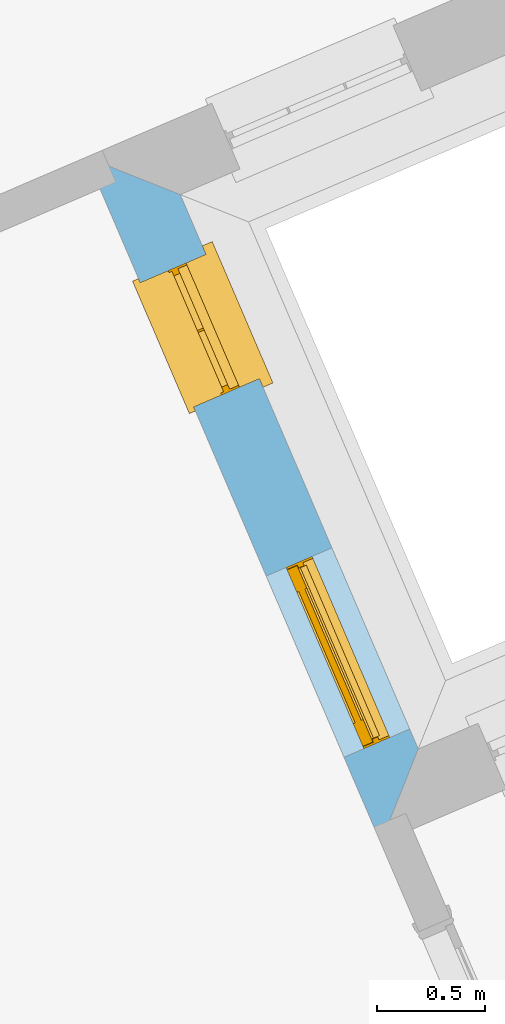
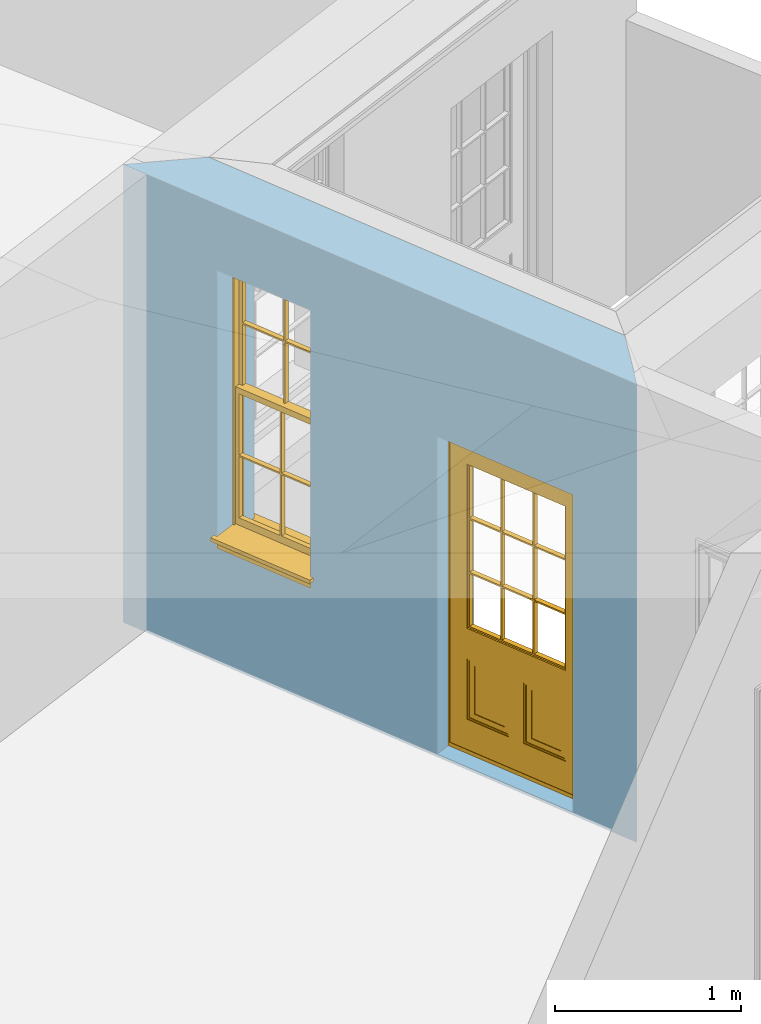
# One storey, part 12 of 19: 1 door, 1 window, 2 openings, plus 1 element that does not belong to this part.
"""IFC2X3 building model written with IfcOpenShell, lengths in metres."""

from ifc_helpers import new_model, si_unit, frame, origin, place, context, subcontext, project, spatial, polyline, outline, extrude, faceted_brep, material, layer, layer_set, layer_usage, element, fill, save


model = new_model("IFC2X3")

# Units and contexts
model_context = context("Model", 3, world=origin())
body_context = subcontext(model_context, "Body", "Model", "MODEL_VIEW")
ifc_project = project(units=[si_unit("PLANEANGLEUNIT", "RADIAN"), si_unit("MASSUNIT", "GRAM", prefix="KILO"), si_unit("FORCEUNIT", "NEWTON", prefix="KILO"), si_unit("LENGTHUNIT", "METRE")], contexts=[model_context])

# Site, building, storey
site_placement = place(None, origin())
site = spatial("IfcSite", under=ifc_project, at=site_placement, CompositionType="ELEMENT")
building_placement = place(None, origin())
building = spatial("IfcBuilding", under=site, at=building_placement, Name="Building plot-0", CompositionType="ELEMENT")
storey_placement = place(None, origin())
storey = spatial("IfcBuildingStorey", under=building, at=storey_placement, Name="Floor 0", CompositionType="ELEMENT", Elevation=0.0)

# Wall, openings, door, window
ifc_material = material(Name="Masonry")
ifc_layer = layer(ifc_material, 0.33, ventilated=False)
ifc_layer_set = layer_set([ifc_layer], Name="My Wall")
ifc_layer_usage = layer_usage(ifc_layer_set, "AXIS2", "NEGATIVE", 0.08)
wall_placement = place(storey_placement, origin())
wall = element("IfcWallStandardCase", 1, at=wall_placement, inside=storey, material=ifc_layer_usage, Name="exterior", context=body_context, shape_type="SweptSolid", body=[
    extrude(outline(polyline([(21.6255021072185, 29.8612650519367), (21.7985578106213, 30.2946836988818), (20.7003749450695, 32.8527272164698), (20.2669562981244, 33.0257829198726), (21.6255021072185, 29.8612650519367)])), origin(), (0.0, 0.0, 1.0), 3.0),
])
opening_1_placement = place(storey_placement, frame((0.0, 0.0, 0.02)))
opening_1 = element("IfcOpeningElement", 2, at=opening_1_placement, cuts=wall, Name="Opening", ObjectType="Opening", context=body_context, shape_type="SweptSolid", body=[
    extrude(outline(polyline([(21.7591088797815, 30.3865737519649), (21.4001236091397, 31.2227732350203), (21.0968864339658, 31.0925917632491), (21.4558717046075, 30.2563922801937), (21.7591088797815, 30.3865737519649)])), origin(), (0.0, 0.0, 1.0), 2.08),
])
opening_2_placement = place(storey_placement, frame((0.0, 0.0, 0.75)))
opening_2 = element("IfcOpeningElement", 3, at=opening_2_placement, cuts=wall, Name="Opening", ObjectType="Opening", context=body_context, shape_type="SweptSolid", body=[
    extrude(outline(polyline([(21.0652775553373, 32.0027442254519), (20.8187217375888, 32.5770570572208), (20.5154845624148, 32.4468755854496), (20.7620403801633, 31.8725627536807), (21.0652775553373, 32.0027442254519)])), origin(), (0.0, 0.0, 1.0), 1.82),
])
door_placement = place(storey_placement, frame((21.529383747074, 30.2879514248655, 0.02), z_axis=(0.0, 0.0, 1.0), x_axis=(-0.358985270641764, 0.836199483055484, 0.0)))
door = element("IfcDoor", 4, at=door_placement, inside=storey, Name="circulation outside door", OverallHeight=2.08, OverallWidth=0.91, context=body_context, shape_type="Brep", held_by="IfcProductRepresentation", body=[
    faceted_brep([(0.545, -0.055, 0.265), (0.745, -0.055, 0.265), (0.745, -0.05, 0.265), (0.545, -0.05, 0.265), (0.745, -0.05, 0.58), (0.545, -0.05, 0.58), (0.545, -0.055, 0.58), (0.515, -0.06, 0.235), (0.775, -0.06, 0.235), (0.745, -0.055, 0.58), (0.515, -0.06, 0.61), (0.515, -0.065, 0.235), (0.775, -0.065, 0.235), (0.775, -0.06, 0.61), (0.515, -0.065, 0.61), (0.785, -0.065, 0.225), (0.505, -0.065, 0.225), (0.775, -0.065, 0.61), (0.505, -0.065, 0.62), (0.785, -0.065, 0.62), (0.505, -0.07, 0.225), (0.785, -0.07, 0.225), (0.505, -0.07, 0.62), (0.785, -0.07, 0.62), (0.883, -0.07, 0.075), (0.898, -0.07, 0.075), (0.405, -0.07, 0.62), (0.405, -0.07, 0.225), (0.027, -0.07, 0.075), (0.785, -0.07, 0.82), (0.125, -0.07, 0.82), (0.405, -0.065, 0.62), (0.405, -0.065, 0.225), (0.898, -0.07, 2.068), (0.027, -0.08, 0.075), (0.883, -0.08, 0.075), (0.125, -0.07, 0.225), (0.012, -0.07, 0.075), (0.785, -0.06, 0.82), (0.125, -0.06, 0.82), (0.125, -0.07, 0.62), (0.125, -0.065, 0.62), (0.395, -0.065, 0.61), (0.395, -0.065, 0.235), (0.125, -0.065, 0.225), (0.785, -0.07, 1.895), (0.027, -0.11, 0.045), (0.883, -0.11, 0.045), (0.558333, -0.06, 0.83), (0.351667, -0.06, 0.83), (0.125, -0.07, 1.895), (0.125, -0.06, 1.895), (0.785, -0.06, 1.895), (0.012, -0.07, 2.068), (0.135, -0.065, 0.61), (0.395, -0.06, 0.61), (0.395, -0.06, 0.235), (0.135, -0.065, 0.235), (0.027, -0.11, 0.027), (0.883, -0.11, 0.027), (0.568333, -0.06, 0.83), (0.558333, -0.03, 0.83), (0.351667, -0.03, 0.83), (0.341667, -0.06, 0.83), (0.135, -0.06, 1.185), (0.135, -0.06, 1.53), (0.775, -0.06, 1.53), (0.775, -0.06, 1.185), (0.135, -0.06, 0.61), (0.365, -0.055, 0.58), (0.365, -0.055, 0.265), (0.135, -0.06, 0.235), (0.568333, -0.06, 1.175), (0.558333, -0.06, 1.175), (0.775, -0.06, 0.83), (0.558333, -0.03, 1.175), (0.785, -0.03, 0.82), (0.125, -0.03, 0.82), (0.351667, -0.03, 1.175), (0.351667, -0.06, 1.175), (0.341667, -0.06, 1.175), (0.135, -0.06, 0.83), (0.135, -0.06, 1.175), (0.135, -0.03, 1.185), (0.135, -0.03, 1.53), (0.135, -0.06, 1.54), (0.351667, -0.06, 1.885), (0.558333, -0.06, 1.885), (0.775, -0.03, 1.53), (0.775, -0.03, 1.185), (0.775, -0.06, 1.175), (0.775, -0.06, 1.54), (0.165, -0.055, 0.58), (0.365, -0.05, 0.58), (0.365, -0.05, 0.265), (0.165, -0.055, 0.265), (0.568333, -0.03, 0.83), (0.568333, -0.03, 1.175), (0.568333, -0.06, 1.185), (0.558333, -0.06, 1.185), (0.775, -0.03, 0.83), (0.785, -0.02, 0.82), (0.125, -0.02, 0.82), (0.341667, -0.03, 0.83), (0.341667, -0.03, 1.175), (0.351667, -0.06, 1.185), (0.341667, -0.06, 1.185), (0.135, -0.03, 0.83), (0.341667, -0.03, 1.185), (0.125, -0.03, 1.895), (0.341667, -0.03, 1.53), (0.341667, -0.06, 1.53), (0.135, -0.06, 1.885), (0.341667, -0.06, 1.54), (0.341667, -0.06, 1.885), (0.558333, -0.03, 1.885), (0.351667, -0.03, 1.885), (0.568333, -0.06, 1.885), (0.785, -0.03, 1.895), (0.568333, -0.03, 1.185), (0.568333, -0.06, 1.53), (0.568333, -0.03, 1.53), (0.568333, -0.06, 1.54), (0.775, -0.06, 1.885), (0.165, -0.05, 0.58), (0.165, -0.05, 0.265), (0.775, -0.03, 1.175), (0.558333, -0.06, 1.53), (0.351667, -0.03, 1.185), (0.558333, -0.03, 1.185), (0.505, -0.02, 0.62), (0.405, -0.02, 0.62), (0.125, -0.02, 1.895), (0.785, -0.02, 1.895), (0.351667, -0.06, 1.53), (0.135, -0.03, 1.175), (0.135, -0.03, 1.54), (0.341667, -0.03, 1.54), (0.135, -0.03, 1.885), (0.351667, -0.06, 1.54), (0.558333, -0.03, 1.54), (0.558333, -0.06, 1.54), (0.351667, -0.03, 1.54), (0.775, -0.03, 1.54), (0.568333, -0.03, 1.54), (0.775, -0.03, 1.885), (0.558333, -0.03, 1.53), (0.405, -0.02, 0.225), (0.505, -0.02, 0.225), (0.125, -0.02, 0.62), (0.785, -0.02, 0.62), (0.012, -0.02, 2.068), (0.898, -0.02, 2.068), (0.351667, -0.03, 1.53), (0.341667, -0.03, 1.885), (0.568333, -0.03, 1.885), (0.405, -0.025, 0.225), (0.405, -0.025, 0.62), (0.505, -0.025, 0.62), (0.505, -0.025, 0.225), (0.898, -0.02, 0.027), (0.012, -0.02, 0.027), (0.125, -0.025, 0.62), (0.785, -0.025, 0.62), (0.395, -0.025, 0.235), (0.395, -0.025, 0.61), (0.125, -0.02, 0.225), (0.125, -0.025, 0.225), (0.515, -0.025, 0.61), (0.515, -0.025, 0.235), (0.785, -0.02, 0.225), (0.785, -0.025, 0.225), (0.135, -0.025, 0.61), (0.775, -0.025, 0.61), (0.135, -0.025, 0.235), (0.395, -0.03, 0.235), (0.395, -0.03, 0.61), (0.515, -0.03, 0.61), (0.515, -0.03, 0.235), (0.775, -0.025, 0.235), (0.135, -0.03, 0.61), (0.775, -0.03, 0.61), (0.135, -0.03, 0.235), (0.365, -0.035, 0.265), (0.365, -0.035, 0.58), (0.545, -0.035, 0.58), (0.545, -0.035, 0.265), (0.775, -0.03, 0.235), (0.165, -0.035, 0.58), (0.745, -0.035, 0.58), (0.165, -0.035, 0.265), (0.365, -0.04, 0.58), (0.365, -0.04, 0.265), (0.545, -0.04, 0.58), (0.545, -0.04, 0.265), (0.745, -0.035, 0.265), (0.165, -0.04, 0.58), (0.745, -0.04, 0.58), (0.165, -0.04, 0.265), (0.745, -0.04, 0.265), (0.885, -0.072, 0.025), (0.025, -0.072, 0.025), (0.025, -0.1, 0.025), (0.885, -0.1, 0.025), (0.9, -0.02, 0.025), (0.01, -0.02, 0.025), (0.9, -0.072, 0.025), (0.91, -0.02, 0.0), (0.0, -0.02, 0.0), (0.01, -0.072, 0.025), (0.9, -0.072, 2.07), (0.9, -0.02, 2.07), (0.885, -0.072, 2.055), (0.91, -0.02, 2.08), (0.01, -0.02, 2.07), (0.0, -0.02, 2.08), (0.01, -0.072, 2.07), (0.025, -0.072, 2.055), (0.0, -0.15, 2.08), (0.91, -0.15, 2.08), (0.01, -0.15, 2.07), (0.9, -0.15, 2.07), (0.01, -0.1, 2.07), (0.9, -0.1, 2.07), (0.0, -0.15, 0.0), (0.91, -0.15, 0.0), (0.01, -0.15, 0.025), (0.9, -0.15, 0.025), (0.01, -0.1, 0.025), (0.025, -0.1, 2.055), (0.9, -0.1, 0.025), (0.885, -0.1, 2.055), (0.898, -0.07, 0.027), (0.012, -0.07, 0.027), (0.883, -0.07, 0.027), (0.027, -0.07, 0.027)], [[[0, 1, 2, 3]], [[2, 4, 5, 3]], [[0, 3, 5, 6]], [[1, 0, 7, 8]], [[9, 4, 2, 1]], [[9, 6, 5, 4]], [[0, 6, 10, 7]], [[8, 7, 11, 12]], [[8, 13, 9, 1]], [[13, 10, 6, 9]], [[7, 10, 14, 11]], [[15, 12, 11, 16]], [[12, 17, 13, 8]], [[17, 14, 10, 13]], [[18, 16, 11, 14]], [[15, 19, 17, 12]], [[15, 16, 20, 21]], [[14, 17, 19, 18]], [[16, 18, 22, 20]], [[21, 23, 19, 15]], [[24, 25, 21, 20]], [[23, 22, 18, 19]], [[20, 22, 26, 27]], [[23, 21, 25]], [[28, 24, 20, 27]], [[22, 23, 29]], [[29, 30, 26, 22]], [[27, 26, 31, 32]], [[23, 25, 33, 29]], [[34, 35, 24, 28]], [[28, 27, 36, 37]], [[38, 39, 30, 29]], [[26, 30, 40]], [[26, 40, 41, 31]], [[42, 43, 32, 31]], [[32, 44, 36, 27]], [[33, 45, 29]], [[46, 47, 35, 34]], [[36, 40, 37]], [[39, 38, 48, 49]], [[50, 30, 39, 51]], [[29, 45, 52, 38]], [[53, 37, 40, 30]], [[44, 41, 40, 36]], [[31, 41, 54, 42]], [[43, 42, 55, 56]], [[57, 44, 32, 43]], [[50, 45, 33, 53]], [[47, 46, 58, 59]], [[60, 48, 38]], [[49, 48, 61, 62]], [[49, 63, 39]], [[50, 53, 30]], [[51, 39, 64, 65]], [[45, 50, 51, 52]], [[66, 67, 38, 52]], [[57, 54, 41, 44]], [[42, 54, 68, 55]], [[56, 55, 69, 70]], [[56, 71, 57, 43]], [[60, 72, 73, 48]], [[60, 38, 74]], [[48, 73, 75, 61]], [[76, 77, 62, 61]], [[62, 78, 79, 49]], [[49, 79, 80, 63]], [[63, 81, 39]], [[82, 64, 39]], [[65, 64, 83, 84]], [[85, 51, 65]], [[52, 51, 86, 87]], [[88, 89, 67, 66]], [[90, 38, 67]], [[91, 66, 52]], [[71, 68, 54, 57]], [[55, 68, 92, 69]], [[69, 93, 94, 70]], [[70, 95, 71, 56]], [[96, 97, 72, 60]], [[73, 72, 98, 99]], [[74, 38, 90]], [[100, 96, 60, 74]], [[75, 73, 79, 78]], [[61, 75, 97, 96]], [[101, 102, 77, 76]], [[77, 103, 62]], [[96, 76, 61]], [[103, 104, 78, 62]], [[80, 79, 105, 106]], [[63, 80, 104, 103]], [[81, 63, 103, 107]], [[81, 82, 39]], [[106, 64, 82, 80]], [[106, 108, 83, 64]], [[84, 83, 77, 109]], [[110, 111, 65, 84]], [[112, 51, 85]], [[113, 85, 65, 111]], [[114, 86, 51]], [[115, 87, 86, 116]], [[117, 52, 87]], [[118, 76, 89, 88]], [[119, 98, 67, 89]], [[120, 121, 88, 66]], [[67, 98, 72, 90]], [[91, 122, 120, 66]], [[91, 52, 123]], [[95, 92, 68, 71]], [[69, 92, 124, 93]], [[94, 93, 124, 125]], [[94, 125, 95, 70]], [[72, 97, 126, 90]], [[127, 99, 98, 120]], [[99, 105, 79, 73]], [[74, 90, 126, 100]], [[96, 100, 76]], [[128, 129, 75, 78]], [[97, 75, 129, 119]], [[130, 131, 102, 101]], [[109, 77, 102, 132]], [[133, 101, 76, 118]], [[77, 107, 103]], [[78, 104, 108, 128]], [[111, 106, 105, 134]], [[104, 80, 82, 135]], [[107, 135, 82, 81]], [[110, 108, 106, 111]], [[104, 135, 83, 108]], [[83, 135, 77]], [[136, 84, 109]], [[110, 84, 136, 137]], [[114, 51, 112]], [[85, 136, 138, 112]], [[113, 137, 136, 85]], [[111, 134, 139, 113]], [[86, 114, 113, 139]], [[140, 141, 87, 115]], [[139, 142, 116, 86]], [[109, 118, 115, 116]], [[117, 123, 52]], [[117, 87, 141, 122]], [[126, 89, 76]], [[143, 118, 88]], [[120, 98, 119, 121]], [[119, 89, 126, 97]], [[144, 143, 88, 121]], [[144, 122, 91, 143]], [[127, 120, 122, 141]], [[143, 91, 123, 145]], [[124, 92, 95, 125]], [[146, 129, 99, 127]], [[99, 129, 128, 105]], [[100, 126, 76]], [[121, 119, 129, 146]], [[147, 131, 130, 148]], [[131, 149, 102]], [[130, 101, 150]], [[102, 151, 132]], [[118, 109, 132, 133]], [[101, 133, 152]], [[107, 77, 135]], [[153, 128, 108, 110]], [[134, 105, 128, 153]], [[109, 138, 136]], [[153, 110, 137, 142]], [[154, 114, 112, 138]], [[137, 113, 114, 154]], [[141, 139, 134, 127]], [[141, 140, 142, 139]], [[144, 140, 115, 155]], [[142, 137, 154, 116]], [[155, 115, 118]], [[116, 154, 109]], [[117, 155, 145, 123]], [[122, 144, 155, 117]], [[143, 145, 118]], [[121, 146, 140, 144]], [[146, 127, 134, 153]], [[156, 157, 131, 147]], [[148, 130, 158, 159]], [[148, 160, 161, 147]], [[157, 162, 149, 131]], [[161, 151, 102, 149]], [[101, 152, 160, 150]], [[163, 158, 130, 150]], [[151, 152, 133, 132]], [[154, 138, 109]], [[142, 140, 146, 153]], [[145, 155, 118]], [[157, 156, 164, 165]], [[147, 166, 167, 156]], [[168, 169, 159, 158]], [[170, 148, 159, 171]], [[148, 170, 160]], [[166, 147, 161]], [[172, 162, 157, 165]], [[166, 149, 162, 167]], [[166, 161, 149]], [[150, 160, 170]], [[163, 173, 168, 158]], [[171, 163, 150, 170]], [[174, 164, 156, 167]], [[175, 176, 165, 164]], [[169, 168, 177, 178]], [[171, 159, 169, 179]], [[167, 162, 172, 174]], [[176, 180, 172, 165]], [[179, 173, 163, 171]], [[181, 177, 168, 173]], [[164, 174, 182, 175]], [[183, 184, 176, 175]], [[178, 177, 185, 186]], [[179, 169, 178, 187]], [[174, 172, 180, 182]], [[184, 188, 180, 176]], [[187, 181, 173, 179]], [[189, 185, 177, 181]], [[175, 182, 190, 183]], [[191, 184, 183, 192]], [[185, 193, 194, 186]], [[187, 178, 186, 195]], [[182, 180, 188, 190]], [[191, 196, 188, 184]], [[195, 189, 181, 187]], [[197, 193, 185, 189]], [[183, 190, 198, 192]], [[198, 196, 191, 192]], [[194, 193, 197, 199]], [[195, 186, 194, 199]], [[188, 196, 198, 190]], [[197, 189, 195, 199]], [[200, 201, 202, 203]], [[201, 200, 204, 205]], [[206, 204, 200]], [[204, 207, 208, 205]], [[209, 201, 205]], [[210, 211, 204, 206]], [[206, 200, 212, 210]], [[211, 213, 207, 204]], [[214, 205, 208, 215]], [[216, 217, 201, 209]], [[205, 214, 216, 209]], [[216, 214, 211, 210]], [[210, 212, 217, 216]], [[214, 215, 213, 211]], [[218, 219, 213, 215]], [[219, 218, 220, 221]], [[221, 220, 222, 223]], [[215, 208, 224, 218]], [[225, 224, 208, 207]], [[224, 226, 220, 218]], [[224, 225, 227, 226]], [[219, 225, 207, 213]], [[228, 222, 220, 226]], [[219, 221, 227, 225]], [[226, 227, 203, 202]], [[202, 229, 222, 228]], [[228, 226, 202]], [[227, 221, 223, 230]], [[230, 203, 227]], [[217, 229, 202, 201]], [[231, 223, 222, 229]], [[230, 223, 231, 203]], [[231, 229, 217, 212]], [[212, 200, 203, 231]], [[33, 152, 151, 53]], [[25, 160, 152, 33]], [[161, 37, 53, 151]], [[232, 160, 25]], [[161, 233, 37]], [[160, 232, 234]], [[24, 234, 232, 25]], [[233, 161, 235]], [[37, 233, 235, 28]], [[161, 160, 234, 235]], [[35, 47, 234, 24]], [[28, 235, 46, 34]], [[58, 235, 234, 59]], [[59, 234, 47]], [[58, 46, 235]]]),
])
fill(opening_1, door)
window_placement = place(storey_placement, frame((20.8355524226297, 31.9041218983525, 0.75), z_axis=(0.0, 0.0, 1.0), x_axis=(-0.246555817748465, 0.574312831768879, 0.0)))
window = element("IfcWindow", 5, at=window_placement, inside=storey, Name="circulation outside window", OverallHeight=1.82, OverallWidth=0.625, context=body_context, shape_type="Brep", held_by="IfcProductRepresentation", body=[
    faceted_brep([(0.033125, -0.105, 0.975209), (0.01, -0.105, 0.975209), (0.033125, -0.105, 1.376042), (0.591875, -0.105, 0.975209), (0.591875, -0.105, 1.376042), (0.615, -0.105, 0.975209), (0.591875, -0.105, 1.386042), (0.591875, -0.105, 1.786875), (0.615, -0.105, 1.81), (0.033125, -0.105, 1.786875), (0.033125, -0.105, 1.386042), (0.01, -0.105, 1.81), (0.591875, -0.135, 1.376042), (0.591875, -0.135, 0.975209), (0.615, -0.135, 0.937083), (0.033125, -0.135, 1.786875), (0.01, -0.135, 1.81), (0.033125, -0.135, 1.386042), (0.01, -0.135, 0.937083), (0.033125, -0.135, 0.975209), (0.033125, -0.135, 1.376042), (0.591875, -0.135, 1.786875), (0.591875, -0.135, 1.386042), (0.615, -0.135, 1.81), (0.033125, -0.105, 0.937083), (0.01, -0.105, 0.937083), (0.033125, -0.105, 0.53625), (0.591875, -0.105, 0.937083), (0.591875, -0.105, 0.53625), (0.615, -0.105, 0.937083), (0.591875, -0.105, 0.52625), (0.591875, -0.105, 0.125417), (0.615, -0.105, 0.077167), (0.033125, -0.105, 0.125417), (0.033125, -0.105, 0.52625), (0.01, -0.105, 0.077167), (-0.0425, -0.25, 0.01), (-0.0425, -0.3, 0.001667), (0.0, -0.25, 0.01), (0.6675, -0.25, 0.01), (0.625, -0.25, 0.01), (0.6675, -0.3, 0.001667), (-0.02, 0.08, 0.077167), (0.0, 0.08, 0.077167), (-0.02, 0.11, 0.077167), (0.0, -0.06, 0.077167), (0.01, -0.06, 0.077167), (0.625, -0.06, 0.077167), (0.625, 0.08, 0.077167), (0.615, -0.06, 0.077167), (0.645, 0.08, 0.077167), (0.645, 0.11, 0.077167), (0.01, -0.075, 0.975209), (0.615, -0.075, 0.975209), (0.591875, -0.075, 0.125417), (0.591875, -0.075, 0.52625), (0.615, -0.075, 0.077167), (0.591875, -0.075, 0.53625), (0.591875, -0.075, 0.937083), (0.033125, -0.075, 0.125417), (0.01, -0.075, 0.077167), (0.033125, -0.075, 0.52625), (0.033125, -0.075, 0.937083), (0.033125, -0.075, 0.53625), (-0.02, 0.08, 0.052167), (-0.02, 0.11, 0.052167), (0.645, 0.11, 0.052167), (0.645, 0.08, 0.052167), (0.625, 0.08, 0.052167), (0.0, 0.08, 0.052167), (0.625, -0.15, 0.026667), (0.0, -0.15, 0.026667), (-0.0425, -0.3, -0.123333), (0.6675, -0.3, -0.123333), (-0.0425, -0.25, -0.123333), (0.6675, -0.25, -0.123333), (0.01, -0.06, 1.81), (0.615, -0.06, 1.81), (0.0, -0.06, 1.82), (0.625, -0.06, 1.82), (0.01, -0.15, 0.077167), (0.615, -0.15, 0.077167), (0.3175, -0.075, 0.53625), (0.3175, -0.105, 0.53625), (0.3175, -0.075, 0.52625), (0.3175, -0.075, 0.125417), (0.3075, -0.075, 0.125417), (0.3075, -0.075, 0.52625), (0.3075, -0.075, 0.53625), (0.3175, -0.075, 0.937083), (0.3075, -0.075, 0.937083), (0.3075, -0.105, 0.52625), (0.3075, -0.105, 0.125417), (0.3175, -0.105, 0.125417), (0.3175, -0.105, 0.52625), (0.3075, -0.105, 0.53625), (0.3075, -0.105, 0.937083), (0.3175, -0.105, 0.937083), (0.3075, -0.135, 1.386042), (0.3075, -0.135, 1.376042), (0.3175, -0.135, 1.376042), (0.3075, -0.135, 0.975209), (0.3175, -0.135, 0.975209), (0.3175, -0.135, 1.786875), (0.3075, -0.135, 1.786875), (0.3175, -0.135, 1.386042), (0.3175, -0.105, 1.386042), (0.3175, -0.105, 1.376042), (0.3075, -0.105, 1.386042), (0.3075, -0.105, 1.786875), (0.3175, -0.105, 1.786875), (0.3075, -0.105, 1.376042), (0.3175, -0.105, 0.975209), (0.3075, -0.105, 0.975209), (0.625, -0.15, 1.82), (0.615, -0.15, 1.81), (0.01, -0.15, 1.81), (0.0, -0.15, 1.82), (0.625, -0.25, 0.0), (0.0, -0.25, 0.0), (0.625, 0.08, 0.0), (0.0, 0.08, 0.0)], [[[0, 1, 2]], [[3, 4, 5]], [[6, 7, 8]], [[9, 10, 11]], [[12, 13, 14]], [[15, 16, 17]], [[18, 19, 20]], [[21, 22, 23]], [[24, 25, 26]], [[27, 28, 29]], [[30, 31, 32]], [[33, 34, 35]], [[14, 27, 29]], [[25, 24, 18]], [[36, 37, 38]], [[39, 40, 41]], [[42, 43, 44]], [[45, 46, 43]], [[47, 48, 49]], [[50, 51, 48]], [[1, 0, 52]], [[5, 53, 3]], [[54, 55, 56]], [[57, 58, 53]], [[59, 60, 61]], [[62, 63, 52]], [[48, 43, 46, 49]], [[51, 44, 43, 48]], [[64, 42, 44, 65]], [[65, 44, 51, 66]], [[66, 51, 50, 67]], [[65, 66, 68, 69]], [[60, 56, 49, 46]], [[70, 71, 38, 40]], [[37, 41, 40, 38]], [[37, 72, 73, 41]], [[74, 75, 73, 72]], [[8, 11, 76, 77]], [[76, 78, 79, 77]], [[32, 35, 80, 81]], [[81, 80, 71, 70]], [[28, 57, 82, 83]], [[84, 85, 86, 87]], [[88, 87, 61, 63]], [[89, 82, 88, 90]], [[84, 82, 57, 55]], [[91, 87, 86, 92]], [[34, 61, 87, 91]], [[93, 85, 84, 94]], [[95, 88, 63, 26]], [[96, 90, 88, 95]], [[83, 82, 89, 97]], [[94, 84, 55, 30]], [[94, 30, 28, 83]], [[94, 91, 92, 93]], [[95, 26, 34, 91]], [[97, 96, 95, 83]], [[98, 17, 20, 99]], [[100, 99, 101, 102]], [[103, 104, 98, 105]], [[100, 12, 22, 105]], [[106, 6, 4, 107]], [[106, 108, 109, 110]], [[111, 2, 10, 108]], [[112, 113, 111, 107]], [[99, 111, 113, 101]], [[20, 2, 111, 99]], [[102, 112, 107, 100]], [[98, 108, 10, 17]], [[104, 109, 108, 98]], [[105, 106, 110, 103]], [[22, 6, 106, 105]], [[100, 107, 4, 12]], [[82, 84, 87, 88]], [[83, 95, 91, 94]], [[99, 100, 105, 98]], [[107, 111, 108, 106]], [[92, 86, 59, 33]], [[15, 9, 109, 104]], [[103, 110, 7, 21]], [[31, 54, 85, 93]], [[36, 74, 72, 37]], [[39, 41, 73, 75]], [[18, 14, 102, 101]], [[23, 16, 104, 103]], [[85, 56, 60, 86]], [[52, 53, 89, 90]], [[53, 52, 113, 112]], [[11, 8, 110, 109]], [[14, 18, 96, 97]], [[2, 1, 11, 10]], [[8, 5, 4, 6]], [[57, 53, 56, 55]], [[60, 52, 63, 61]], [[26, 25, 35, 34]], [[32, 29, 28, 30]], [[14, 23, 22, 12]], [[18, 20, 17, 16]], [[19, 0, 2, 20]], [[17, 10, 9, 15]], [[12, 4, 3, 13]], [[21, 7, 6, 22]], [[27, 58, 57, 28]], [[30, 55, 54, 31]], [[33, 59, 61, 34]], [[26, 63, 62, 24]], [[5, 8, 77, 53]], [[76, 11, 1, 52]], [[46, 45, 78, 76]], [[49, 77, 79, 47]], [[70, 114, 115, 81]], [[71, 80, 116, 117]], [[19, 101, 113, 0]], [[102, 13, 3, 112]], [[90, 96, 24, 62]], [[29, 32, 81, 14]], [[80, 35, 25, 18]], [[60, 46, 76, 52]], [[77, 49, 56, 53]], [[23, 14, 81, 115]], [[16, 116, 80, 18]], [[92, 33, 35]], [[32, 31, 93]], [[32, 93, 92, 35]], [[14, 13, 102]], [[101, 19, 18]], [[103, 21, 23]], [[16, 15, 104]], [[109, 9, 11]], [[8, 7, 110]], [[23, 115, 116, 16]], [[114, 117, 116, 115]], [[90, 62, 52]], [[58, 89, 53]], [[27, 97, 89, 58]], [[85, 54, 56]], [[60, 59, 86]], [[97, 27, 14]], [[18, 24, 96]], [[52, 0, 113]], [[112, 3, 53]], [[79, 78, 117, 114]], [[78, 45, 71, 117]], [[114, 70, 47, 79]], [[118, 75, 74, 119]], [[68, 66, 67]], [[48, 68, 67, 50]], [[69, 64, 65]], [[42, 64, 69, 43]], [[69, 68, 120, 121]], [[70, 68, 48, 47]], [[118, 120, 68, 70]], [[43, 69, 71, 45]], [[69, 121, 119, 71]], [[120, 118, 119, 121]], [[38, 119, 74, 36]], [[71, 119, 38]], [[39, 75, 118, 40]], [[40, 118, 70]]]),
])
fill(opening_2, window)

save(model, "model.ifc")
